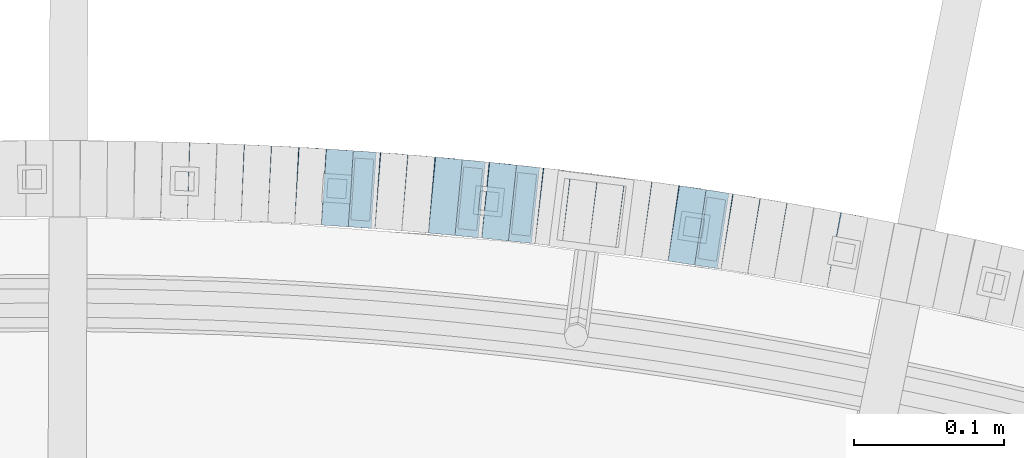
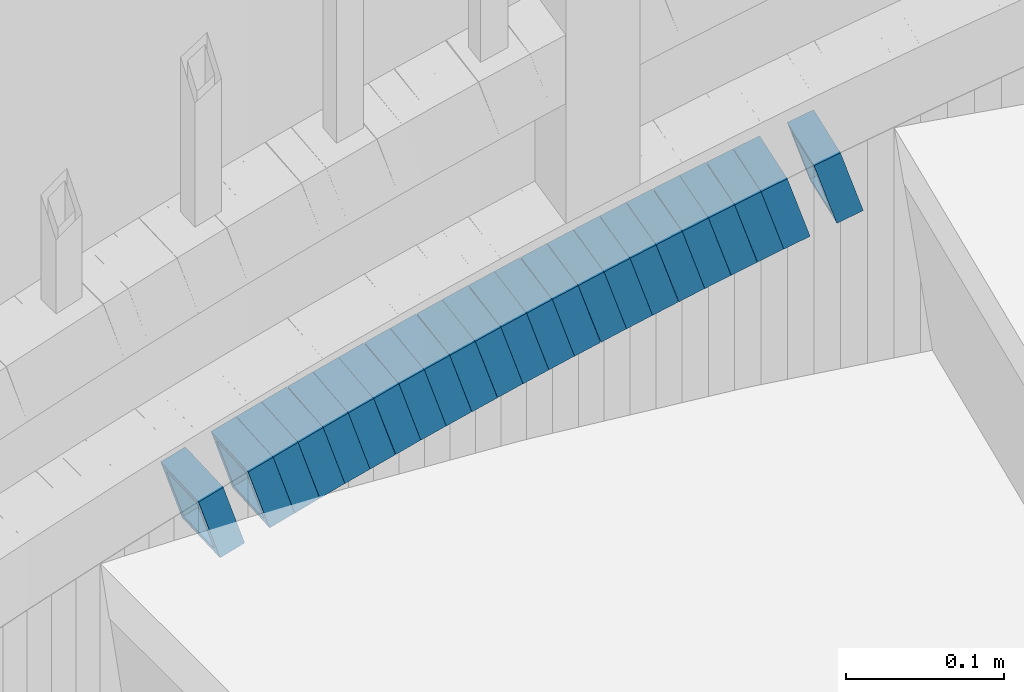
# One storey, part 820 of 975: 23 beams.
"""IFC2X3 building model written with IfcOpenShell, lengths in millimetres."""

from ifc_helpers import new_model, si_unit, frame, origin_with_axes, place, context, subcontext, project, spatial, faceted_brep, material, type_object, element, save


model = new_model("IFC2X3")

# Units and contexts
model_context = context("Model", 3, precision=1e-05, world=origin_with_axes())
body_context = subcontext(model_context, "Body", "Model", "MODEL_VIEW")
ifc_project = project(units=[si_unit("LENGTHUNIT", "METRE", prefix="MILLI"), si_unit("AREAUNIT", "SQUARE_METRE"), si_unit("VOLUMEUNIT", "CUBIC_METRE"), si_unit("MASSUNIT", "GRAM", prefix="KILO"), si_unit("TIMEUNIT", "SECOND"), si_unit("PLANEANGLEUNIT", "RADIAN"), si_unit("SOLIDANGLEUNIT", "STERADIAN"), si_unit("THERMODYNAMICTEMPERATUREUNIT", "DEGREE_CELSIUS"), si_unit("LUMINOUSINTENSITYUNIT", "LUMEN")], contexts=[model_context])

# Site, building, storey
site_placement = place(None, origin_with_axes())
site = spatial("IfcSite", under=ifc_project, at=site_placement, CompositionType="ELEMENT")
building_placement = place(site_placement, origin_with_axes())
building = spatial("IfcBuilding", under=site, at=building_placement, Name="Undefined", CompositionType="ELEMENT")
storey_placement = place(building_placement, origin_with_axes())
storey = spatial("IfcBuildingStorey", under=building, at=storey_placement, Name="Undefined", CompositionType="ELEMENT", Elevation=0.0)

# Beams
ifc_material = material()
beam_type = type_object("IfcBeamType", Name="HSS2X2X.188_TUBES", PredefinedType="NOTDEFINED")
beam_1_placement = place(storey_placement, frame((35262.2063020336, 6225.26838532403, 1208.89888890886), z_axis=(-0.178885438594422, -0.983869910028191, 3.69490862794919e-10), x_axis=(-0.937430905660929, 0.17044198293836, -0.303599781890188)))
element("IfcBeam", 1, at=beam_1_placement, inside=storey, type_object=beam_type, material=ifc_material, Name="WALL", ObjectType="HSS2X2X.188_TUBES", context=body_context, shape_type="Brep", body=[
    faceted_brep([(0.0, 20.6374999999753, -20.6375000000298), (0.0, -20.6375000000153, -20.6375000000153), (18.767258723612, -20.6375000000025, -20.6374999999862), (18.7672587236229, 20.6374999999953, -20.637499999968), (0.0, -20.6374999999825, 20.6375000000335), (18.767258723612, -20.6375000000135, 20.6375000000153), (0.0, 20.6375000000116, 20.6375000000189), (18.7672587236266, 20.6374999999844, 20.6375000000371), (0.0, 25.3999999999724, -25.4000000000342), (0.0, 25.400000000016, 25.4000000000196), (18.7672587236302, 25.3999999999814, 25.4000000000342), (18.7672587236229, 25.399999999996, -25.3999999999687), (0.0, -25.399999999976, 25.4000000000378), (18.7672587236157, -25.4000000000142, 25.400000000016), (0.0, -25.400000000016, -25.4000000000196), (18.767258723612, -25.4000000000015, -25.3999999999905)], [[[0, 1, 2, 3]], [[1, 4, 5, 2]], [[4, 6, 7, 5]], [[6, 0, 3, 7]], [[8, 9, 10, 11]], [[9, 12, 13, 10]], [[12, 14, 15, 13]], [[14, 8, 11, 15]], [[13, 15, 11, 10], [5, 7, 3, 2]], [[14, 12, 9, 8], [6, 4, 1, 0]]]),
])
beam_2_placement = place(storey_placement, frame((35226.658747704, 6231.69836351905, 1197.40322650701), z_axis=(-0.168030974253103, -0.985781716046485, 1.54325334733585e-10), x_axis=(-0.93908413016491, 0.160071159028105, -0.304135201053436)))
element("IfcBeam", 2, at=beam_2_placement, inside=storey, type_object=beam_type, material=ifc_material, Name="WALL", ObjectType="HSS2X2X.188_TUBES", context=body_context, shape_type="Brep", body=[
    faceted_brep([(0.0, 20.6374999999753, -20.6375000000298), (0.0, -20.6375000000153, -20.6375000000153), (18.7416648140024, -20.6375000000153, -20.6374999999825), (18.7416648139188, 20.6375000000189, -20.6375000000298), (0.0, -20.6374999999825, 20.6375000000335), (18.7416648140097, -20.6375000000189, 20.6375000000226), (0.0, 20.6375000000116, 20.6375000000189), (18.741664813926, 20.6375000000153, 20.6374999999753), (0.0, 25.3999999999724, -25.4000000000342), (0.0, 25.400000000016, 25.4000000000196), (18.7416648139224, 25.4000000000196, 25.3999999999687), (18.7416648139042, 25.4000000000233, -25.4000000000378), (0.0, -25.399999999976, 25.4000000000378), (18.7416648140133, -25.4000000000215, 25.4000000000269), (0.0, -25.400000000016, -25.4000000000196), (18.7416648140133, -25.4000000000196, -25.399999999976)], [[[0, 1, 2, 3]], [[1, 4, 5, 2]], [[4, 6, 7, 5]], [[6, 0, 3, 7]], [[8, 9, 10, 11]], [[9, 12, 13, 10]], [[12, 14, 15, 13]], [[14, 8, 11, 15]], [[13, 15, 11, 10], [5, 7, 3, 2]], [[14, 12, 9, 8], [6, 4, 1, 0]]]),
])
beam_3_placement = place(storey_placement, frame((35208.9947502894, 6234.75973884689, 1191.73219557075), z_axis=(-0.161686018393244, -0.986842252569345, 1.71110059454804e-10), x_axis=(-0.938968920147769, 0.15384236502417, -0.307684731048362)))
element("IfcBeam", 3, at=beam_3_placement, inside=storey, type_object=beam_type, material=ifc_material, Name="WALL", ObjectType="HSS2X2X.188_TUBES", context=body_context, shape_type="Brep", body=[
    faceted_brep([(0.0, 20.6374999999753, -20.6375000000298), (0.0, -20.6375000000153, -20.6375000000153), (18.8480768248774, -20.6374999999716, -20.6375000000735), (18.8480768249356, 20.6375000000153, -20.6375000000226), (0.0, -20.6374999999825, 20.6375000000335), (18.8480768249283, -20.6374999999935, 20.6374999999716), (0.0, 20.6375000000116, 20.6375000000189), (18.8480768249865, 20.6374999999935, 20.6375000000262), (0.0, 25.3999999999724, -25.4000000000342), (0.0, 25.400000000016, 25.4000000000196), (18.848076825001, 25.3999999999887, 25.4000000000378), (18.8480768249392, 25.4000000000142, -25.4000000000233), (0.0, -25.399999999976, 25.4000000000378), (18.8480768249283, -25.399999999996, 25.3999999999833), (0.0, -25.400000000016, -25.4000000000196), (18.8480768248664, -25.3999999999687, -25.4000000000779)], [[[0, 1, 2, 3]], [[1, 4, 5, 2]], [[4, 6, 7, 5]], [[6, 0, 3, 7]], [[8, 9, 10, 11]], [[9, 12, 13, 10]], [[12, 14, 15, 13]], [[14, 8, 11, 15]], [[13, 15, 11, 10], [5, 7, 3, 2]], [[14, 12, 9, 8], [6, 4, 1, 0]]]),
])
beam_4_placement = place(storey_placement, frame((35190.9814570241, 6237.78959239048, 1185.90925997112), z_axis=(-0.151635150261849, -0.988436533726403, -9.61329078563721e-11), x_axis=(-0.941378395041395, 0.144416004006362, -0.30487823001343)))
element("IfcBeam", 4, at=beam_4_placement, inside=storey, type_object=beam_type, material=ifc_material, Name="WALL", ObjectType="HSS2X2X.188_TUBES", context=body_context, shape_type="Brep", body=[
    faceted_brep([(0.0, 20.6374999999753, -20.6375000000298), (0.0, -20.6375000000153, -20.6375000000153), (18.6959888745805, -20.6374999999771, -20.6375000000407), (18.6959888746751, 20.637499999988, -20.6374999999716), (0.0, -20.6374999999825, 20.6375000000335), (18.6959888746969, -20.6375000000135, 20.6375000000371), (0.0, 20.6375000000116, 20.6375000000189), (18.6959888747988, 20.6374999999498, 20.6375000001062), (0.0, 25.3999999999724, -25.4000000000342), (0.0, 25.400000000016, 25.4000000000196), (18.695988874817, 25.3999999999414, 25.4000000001215), (18.6959888746678, 25.3999999999887, -25.399999999976), (0.0, -25.399999999976, 25.4000000000378), (18.6959888747042, -25.4000000000124, 25.4000000000378), (0.0, -25.400000000016, -25.4000000000196), (18.695988874555, -25.3999999999687, -25.4000000000597)], [[[0, 1, 2, 3]], [[1, 4, 5, 2]], [[4, 6, 7, 5]], [[6, 0, 3, 7]], [[8, 9, 10, 11]], [[9, 12, 13, 10]], [[12, 14, 15, 13]], [[14, 8, 11, 15]], [[13, 15, 11, 10], [5, 7, 3, 2]], [[14, 12, 9, 8], [6, 4, 1, 0]]]),
])
for number, where, z_axis, x_axis, name in (
    (5, (35173.322819567, 6240.50518047398, 1180.19687075573), (-0.150797989337356, -0.988564599007981, 2.08925030165119e-10), (-0.941982549776804, 0.14369225296595, -0.303350312928075), "WALL"),
    (6, (35155.4898876332, 6243.31159292335, 1174.53992485413), (-0.139854805609597, -0.990172022099141, -1.91347226063954e-10), (-0.941835845386871, 0.133027662054659, -0.308624175126755), "WALL"),
):
    element("IfcBeam", number, at=place(storey_placement, frame(where, z_axis=z_axis, x_axis=x_axis)), inside=storey, type_object=beam_type, material=ifc_material, Name=name, ObjectType="HSS2X2X.188_TUBES", context=body_context, shape_type="Brep", body=[
        faceted_brep([(0.0, 20.6374999999753, -20.6375000000298), (0.0, -20.6375000000153, -20.6375000000153), (18.7853666454903, -20.6375000000535, -20.6375000000326), (18.785366645363, 20.6374999999862, -20.6375000000044), (0.0, -20.6374999999825, 20.6375000000335), (18.785366645352, -20.6375000000007, 20.6374999999989), (0.0, 20.6375000000116, 20.6375000000189), (18.7853666453102, 20.6375000000025, 20.6374999999753), (0.0, 25.3999999999724, -25.4000000000342), (0.0, 25.400000000016, 25.4000000000196), (18.7853666452065, 25.4000000000451, 25.4000000000351), (18.7853666453739, 25.3999999999833, -25.400000000006), (0.0, -25.399999999976, 25.4000000000378), (18.7853666497213, -25.399999993424, 25.3999999995158), (0.0, -25.400000000016, -25.4000000000196), (18.7853666455194, -25.4000000000633, -25.4000000000406)], [[[0, 1, 2, 3]], [[1, 4, 5, 2]], [[4, 6, 7, 5]], [[6, 0, 3, 7]], [[8, 9, 10, 11]], [[9, 12, 13, 10]], [[12, 14, 15, 13]], [[14, 8, 11, 15]], [[13, 15, 11, 10], [5, 7, 3, 2]], [[14, 12, 9, 8], [6, 4, 1, 0]]]),
    ])
beam_5_placement = place(storey_placement, frame((35137.540226941, 6245.8896922411, 1168.70220925751), z_axis=(-0.134363672851374, -0.990932088196708, 5.54321104573319e-11), x_axis=(-0.944030209558858, 0.128004096075806, -0.304009728179996)))
element("IfcBeam", 7, at=beam_5_placement, inside=storey, type_object=beam_type, material=ifc_material, Name="WALL", ObjectType="HSS2X2X.188_TUBES", context=body_context, shape_type="Brep", body=[
    faceted_brep([(0.0, 20.6374999999753, -20.6375000000298), (0.0, -20.6375000000153, -20.6375000000153), (18.7547327359644, -20.6374999999844, -20.6375000000553), (18.7547327359898, 20.6375000000171, -20.6375000000335), (0.0, -20.6374999999825, 20.6375000000335), (18.7547327360044, -20.6374999999953, 20.6374999999898), (0.0, 20.6375000000116, 20.6375000000189), (18.7547327360262, 20.6375000000062, 20.6375000000116), (0.0, 25.3999999999724, -25.4000000000342), (0.0, 25.400000000016, 25.4000000000196), (18.7547327360371, 25.4000000000033, 25.4000000000124), (18.7547327359898, 25.4000000000178, -25.4000000000342), (0.0, -25.399999999976, 25.4000000000378), (18.7547327360044, -25.399999999996, 25.3999999999869), (0.0, -25.400000000016, -25.4000000000196), (18.7547327359498, -25.3999999999814, -25.4000000000597)], [[[0, 1, 2, 3]], [[1, 4, 5, 2]], [[4, 6, 7, 5]], [[6, 0, 3, 7]], [[8, 9, 10, 11]], [[9, 12, 13, 10]], [[12, 14, 15, 13]], [[14, 8, 11, 15]], [[13, 15, 11, 10], [5, 7, 3, 2]], [[14, 12, 9, 8], [6, 4, 1, 0]]]),
])
beam_6_placement = place(storey_placement, frame((35119.7112034117, 6248.3500834073, 1163.00385877007), z_axis=(-0.128860134810282, -0.991662778194622, 6.80909124639584e-11), x_axis=(-0.94466191513395, 0.122752678017421, -0.304213159043145)))
element("IfcBeam", 8, at=beam_6_placement, inside=storey, type_object=beam_type, material=ifc_material, Name="WALL", ObjectType="HSS2X2X.188_TUBES", context=body_context, shape_type="Brep", body=[
    faceted_brep([(0.0, 20.6374999999753, -20.6375000000298), (0.0, -20.6375000000153, -20.6375000000153), (18.7416648140024, -20.6375000000153, -20.6374999999825), (18.7416648139188, 20.6375000000189, -20.6375000000298), (0.0, -20.6374999999825, 20.6375000000335), (18.7416648140097, -20.6375000000189, 20.6375000000226), (0.0, 20.6375000000116, 20.6375000000189), (18.741664813926, 20.6375000000153, 20.6374999999753), (0.0, 25.3999999999724, -25.4000000000342), (0.0, 25.400000000016, 25.4000000000196), (18.7416648139224, 25.4000000000196, 25.3999999999687), (18.7416648139042, 25.4000000000233, -25.4000000000378), (0.0, -25.399999999976, 25.4000000000378), (18.7416648140133, -25.4000000000215, 25.4000000000269), (0.0, -25.400000000016, -25.4000000000196), (18.7416648140133, -25.4000000000196, -25.399999999976)], [[[0, 1, 2, 3]], [[1, 4, 5, 2]], [[4, 6, 7, 5]], [[6, 0, 3, 7]], [[8, 9, 10, 11]], [[9, 12, 13, 10]], [[12, 14, 15, 13]], [[14, 8, 11, 15]], [[13, 15, 11, 10], [5, 7, 3, 2]], [[14, 12, 9, 8], [6, 4, 1, 0]]]),
])
beam_7_placement = place(storey_placement, frame((35102.0032873235, 6250.69475441336, 1157.34502291689), z_axis=(-0.123344664337536, -0.992363891815629, 2.06378899747506e-10), x_axis=(-0.943721538367322, 0.117298722045631, -0.309242086120369)))
element("IfcBeam", 9, at=beam_7_placement, inside=storey, type_object=beam_type, material=ifc_material, Name="WALL", ObjectType="HSS2X2X.188_TUBES", context=body_context, shape_type="Brep", body=[
    faceted_brep([(0.0, 20.6374999999753, -20.6375000000298), (0.0, -20.6375000000153, -20.6375000000153), (18.7555325170906, -20.6374999999916, -20.6374999999971), (18.7555325171452, 20.637499999988, -20.6374999999571), (0.0, -20.6374999999825, 20.6375000000335), (18.7555325170615, -20.6374999999844, 20.6374999999716), (0.0, 20.6375000000116, 20.6375000000189), (18.7555325171015, 20.6374999999953, 20.637500000008), (0.0, 25.3999999999724, -25.4000000000342), (0.0, 25.400000000016, 25.4000000000196), (18.7555325171015, 25.399999999996, 25.4000000000051), (18.7555325171488, 25.3999999999851, -25.3999999999505), (0.0, -25.399999999976, 25.4000000000378), (18.755532517047, -25.3999999999814, 25.3999999999578), (0.0, -25.400000000016, -25.4000000000196), (18.7555325170979, -25.3999999999924, -25.3999999999978)], [[[0, 1, 2, 3]], [[1, 4, 5, 2]], [[4, 6, 7, 5]], [[6, 0, 3, 7]], [[8, 9, 10, 11]], [[9, 12, 13, 10]], [[12, 14, 15, 13]], [[14, 8, 11, 15]], [[13, 15, 11, 10], [5, 7, 3, 2]], [[14, 12, 9, 8], [6, 4, 1, 0]]]),
])
beam_8_placement = place(storey_placement, frame((35083.9963321529, 6252.98069752095, 1151.49454788734), z_axis=(-0.117164953610452, -0.993112467772639, 1.14559497887967e-10), x_axis=(-0.946406940559044, 0.111654750947981, -0.303062896858747)))
element("IfcBeam", 10, at=beam_8_placement, inside=storey, type_object=beam_type, material=ifc_material, Name="WALL", ObjectType="HSS2X2X.188_TUBES", context=body_context, shape_type="Brep", body=[
    faceted_brep([(0.0, 20.6374999999753, -20.6375000000298), (0.0, -20.6375000000153, -20.6375000000153), (18.8066477608099, -20.6374999999862, -20.6375000000116), (18.8066477608172, 20.6375000000062, -20.6374999999971), (0.0, -20.6374999999825, 20.6375000000335), (18.8066477608463, -20.6375000000062, 20.6375000000407), (0.0, 20.6375000000116, 20.6375000000189), (18.8066477608536, 20.6374999999844, 20.637500000048), (0.0, 25.3999999999724, -25.4000000000342), (0.0, 25.400000000016, 25.4000000000196), (18.8066477608591, 25.3999999999814, 25.400000000056), (18.8066477608154, 25.4000000000051, -25.4000000000015), (0.0, -25.399999999976, 25.4000000000378), (18.8066477608518, -25.4000000000087, 25.4000000000451), (0.0, -25.400000000016, -25.4000000000196), (18.8066477608081, -25.3999999999851, -25.4000000000196)], [[[0, 1, 2, 3]], [[1, 4, 5, 2]], [[4, 6, 7, 5]], [[6, 0, 3, 7]], [[8, 9, 10, 11]], [[9, 12, 13, 10]], [[12, 14, 15, 13]], [[14, 8, 11, 15]], [[13, 15, 11, 10], [5, 7, 3, 2]], [[14, 12, 9, 8], [6, 4, 1, 0]]]),
])
beam_9_placement = place(storey_placement, frame((35065.9878684266, 6255.18576919674, 1145.80979211206), z_axis=(-0.106731467305159, -0.994287882802002, 2.14446572499583e-10), x_axis=(-0.946930338465777, 0.101647889050011, -0.304943668149982)))
element("IfcBeam", 11, at=beam_9_placement, inside=storey, type_object=beam_type, material=ifc_material, Name="WALL", ObjectType="HSS2X2X.188_TUBES", context=body_context, shape_type="Brep", body=[
    faceted_brep([(0.0, 20.6374999999753, -20.6375000000298), (0.0, -20.6375000000153, -20.6375000000153), (18.6895692834223, -20.637499999988, -20.6374999999862), (18.6895692834369, 20.6374999999953, -20.6374999999534), (0.0, -20.6374999999825, 20.6375000000335), (18.6895692833914, -20.637499999988, 20.6374999999789), (0.0, 20.6375000000116, 20.6375000000189), (18.6895692834078, 20.6374999999953, 20.637500000008), (0.0, 25.3999999999724, -25.4000000000342), (0.0, 25.400000000016, 25.4000000000196), (18.6895692834059, 25.3999999999924, 25.4000000000087), (18.6895692834423, 25.3999999999942, -25.3999999999432), (0.0, -25.399999999976, 25.4000000000378), (18.6895692833878, -25.3999999999869, 25.3999999999687), (0.0, -25.400000000016, -25.4000000000196), (18.6895692834241, -25.3999999999869, -25.3999999999833)], [[[0, 1, 2, 3]], [[1, 4, 5, 2]], [[4, 6, 7, 5]], [[6, 0, 3, 7]], [[8, 9, 10, 11]], [[9, 12, 13, 10]], [[12, 14, 15, 13]], [[14, 8, 11, 15]], [[13, 15, 11, 10], [5, 7, 3, 2]], [[14, 12, 9, 8], [6, 4, 1, 0]]]),
])
beam_10_placement = place(storey_placement, frame((35048.2344700465, 6257.09611792352, 1140.09732250904), z_axis=(-0.10613862675189, -0.994351342288641, -2.28305907512549e-10), x_axis=(-0.947478931466103, 0.101135391943019, -0.30340617482903)))
element("IfcBeam", 12, at=beam_10_placement, inside=storey, type_object=beam_type, material=ifc_material, Name="WALL", ObjectType="HSS2X2X.188_TUBES", context=body_context, shape_type="Brep", body=[
    faceted_brep([(0.0, 20.6374999999753, -20.6375000000298), (0.0, -20.6375000000153, -20.6375000000153), (18.7853666454903, -20.6375000000535, -20.6375000000326), (18.785366645363, 20.6374999999862, -20.6375000000044), (0.0, -20.6374999999825, 20.6375000000335), (18.785366645352, -20.6375000000007, 20.6374999999989), (0.0, 20.6375000000116, 20.6375000000189), (18.7853666453102, 20.6375000000025, 20.6374999999753), (0.0, 25.3999999999724, -25.4000000000342), (0.0, 25.400000000016, 25.4000000000196), (18.7853666452065, 25.4000000000451, 25.4000000000351), (18.7853666453739, 25.3999999999833, -25.400000000006), (0.0, -25.399999999976, 25.4000000000378), (18.7853666497213, -25.399999993424, 25.3999999995158), (0.0, -25.400000000016, -25.4000000000196), (18.7853666455194, -25.4000000000633, -25.4000000000406)], [[[0, 1, 2, 3]], [[1, 4, 5, 2]], [[4, 6, 7, 5]], [[6, 0, 3, 7]], [[8, 9, 10, 11]], [[9, 12, 13, 10]], [[12, 14, 15, 13]], [[14, 8, 11, 15]], [[13, 15, 11, 10], [5, 7, 3, 2]], [[14, 12, 9, 8], [6, 4, 1, 0]]]),
])
beam_11_placement = place(storey_placement, frame((35030.2918652597, 6259.09741657967, 1134.43924107346), z_axis=(-0.0950730065790194, -0.995470302630885, -1.98346697288798e-10), x_axis=(-0.946902283782616, 0.0904344879792262, -0.30854119392911)))
element("IfcBeam", 13, at=beam_11_placement, inside=storey, type_object=beam_type, material=ifc_material, Name="WALL", ObjectType="HSS2X2X.188_TUBES", context=body_context, shape_type="Brep", body=[
    faceted_brep([(0.0, 20.6374999999753, -20.6375000000298), (0.0, -20.6375000000153, -20.6375000000153), (18.8047866246379, -20.6374999999916, -20.6375000000298), (18.8047866247143, 20.6374999999844, -20.6374999999643), (0.0, -20.6374999999825, 20.6375000000335), (18.8047866247107, -20.6375000000189, 20.6375000000407), (0.0, 20.6375000000116, 20.6375000000189), (18.8047866247907, 20.6374999999589, 20.6375000001026), (0.0, 25.3999999999724, -25.4000000000342), (0.0, 25.400000000016, 25.4000000000196), (18.8047866248016, 25.3999999999542, 25.4000000001142), (18.8047866247143, 25.3999999999851, -25.3999999999651), (0.0, -25.399999999976, 25.4000000000378), (18.8047866247107, -25.4000000000196, 25.4000000000415), (0.0, -25.400000000016, -25.4000000000196), (18.8047866246197, -25.3999999999887, -25.4000000000378)], [[[0, 1, 2, 3]], [[1, 4, 5, 2]], [[4, 6, 7, 5]], [[6, 0, 3, 7]], [[8, 9, 10, 11]], [[9, 12, 13, 10]], [[12, 14, 15, 13]], [[14, 8, 11, 15]], [[13, 15, 11, 10], [5, 7, 3, 2]], [[14, 12, 9, 8], [6, 4, 1, 0]]]),
])
beam_12_placement = place(storey_placement, frame((35012.4219826033, 6260.79992261746, 1128.61235292574), z_axis=(-0.0956052464452732, -0.995419327144163, -1.37664756039157e-10), x_axis=(-0.947907534808326, 0.0910419669816003, -0.305258358938331)))
element("IfcBeam", 14, at=beam_12_placement, inside=storey, type_object=beam_type, material=ifc_material, Name="WALL", ObjectType="HSS2X2X.188_TUBES", context=body_context, shape_type="Brep", body=[
    faceted_brep([(0.0, 20.6374999999753, -20.6375000000298), (0.0, -20.6375000000153, -20.6375000000153), (18.6689581926366, -20.6374999999953, -20.6374999999916), (18.6689581926476, 20.6375000000062, -20.6374999999935), (0.0, -20.6374999999825, 20.6375000000335), (18.6689581927276, -20.6375000000116, 20.6374999999862), (0.0, 20.6375000000116, 20.6375000000189), (18.6689581927312, 20.6374999999862, 20.6374999999844), (0.0, 25.3999999999724, -25.4000000000342), (0.0, 25.400000000016, 25.4000000000196), (18.6689581927458, 25.3999999999833, 25.3999999999814), (18.6689581926366, 25.4000000000087, -25.3999999999905), (0.0, -25.399999999976, 25.4000000000378), (18.6689581927385, -25.4000000000142, 25.3999999999851), (0.0, -25.400000000016, -25.4000000000196), (18.6689581926257, -25.3999999999887, -25.3999999999869)], [[[0, 1, 2, 3]], [[1, 4, 5, 2]], [[4, 6, 7, 5]], [[6, 0, 3, 7]], [[8, 9, 10, 11]], [[9, 12, 13, 10]], [[12, 14, 15, 13]], [[14, 8, 11, 15]], [[13, 15, 11, 10], [5, 7, 3, 2]], [[14, 12, 9, 8], [6, 4, 1, 0]]]),
])
beam_13_placement = place(storey_placement, frame((34994.4025898593, 6262.61946067607, 1122.9020690823), z_axis=(-0.0839720319663465, -0.996468111806616, 5.51881385035813e-12), x_axis=(-0.949309706342227, 0.0799980090288366, -0.303992434109563)))
element("IfcBeam", 15, at=beam_13_placement, inside=storey, type_object=beam_type, material=ifc_material, Name="WALL", ObjectType="HSS2X2X.188_TUBES", context=body_context, shape_type="Brep", body=[
    faceted_brep([(0.0, 20.6374999999753, -20.6375000000298), (0.0, -20.6375000000153, -20.6375000000153), (18.7547327359644, -20.6374999999844, -20.6375000000553), (18.7547327359898, 20.6375000000171, -20.6375000000335), (0.0, -20.6374999999825, 20.6375000000335), (18.7547327360044, -20.6374999999953, 20.6374999999898), (0.0, 20.6375000000116, 20.6375000000189), (18.7547327360262, 20.6375000000062, 20.6375000000116), (0.0, 25.3999999999724, -25.4000000000342), (0.0, 25.400000000016, 25.4000000000196), (18.7547327360371, 25.4000000000033, 25.4000000000124), (18.7547327359898, 25.4000000000178, -25.4000000000342), (0.0, -25.399999999976, 25.4000000000378), (18.7547327360044, -25.399999999996, 25.3999999999869), (0.0, -25.400000000016, -25.4000000000196), (18.7547327359498, -25.3999999999814, -25.4000000000597)], [[[0, 1, 2, 3]], [[1, 4, 5, 2]], [[4, 6, 7, 5]], [[6, 0, 3, 7]], [[8, 9, 10, 11]], [[9, 12, 13, 10]], [[12, 14, 15, 13]], [[14, 8, 11, 15]], [[13, 15, 11, 10], [5, 7, 3, 2]], [[14, 12, 9, 8], [6, 4, 1, 0]]]),
])
beam_14_placement = place(storey_placement, frame((34976.4679778304, 6264.1736704105, 1117.20308609433), z_axis=(-0.0784095351627402, -0.996921232994645, -5.19273726240499e-11), x_axis=(-0.949701466907224, 0.0746956209927166, -0.304117884970253)))
element("IfcBeam", 16, at=beam_14_placement, inside=storey, type_object=beam_type, material=ifc_material, Name="WALL", ObjectType="HSS2X2X.188_TUBES", context=body_context, shape_type="Brep", body=[
    faceted_brep([(0.0, 20.6374999999753, -20.6375000000298), (0.0, -20.6375000000153, -20.6375000000153), (18.7416648140024, -20.6375000000153, -20.6374999999825), (18.7416648139188, 20.6375000000189, -20.6375000000298), (0.0, -20.6374999999825, 20.6375000000335), (18.7416648140097, -20.6375000000189, 20.6375000000226), (0.0, 20.6375000000116, 20.6375000000189), (18.741664813926, 20.6375000000153, 20.6374999999753), (0.0, 25.3999999999724, -25.4000000000342), (0.0, 25.400000000016, 25.4000000000196), (18.7416648139224, 25.4000000000196, 25.3999999999687), (18.7416648139042, 25.4000000000233, -25.4000000000378), (0.0, -25.399999999976, 25.4000000000378), (18.7416648140133, -25.4000000000215, 25.4000000000269), (0.0, -25.400000000016, -25.4000000000196), (18.7416648140133, -25.4000000000196, -25.399999999976)], [[[0, 1, 2, 3]], [[1, 4, 5, 2]], [[4, 6, 7, 5]], [[6, 0, 3, 7]], [[8, 9, 10, 11]], [[9, 12, 13, 10]], [[12, 14, 15, 13]], [[14, 8, 11, 15]], [[13, 15, 11, 10], [5, 7, 3, 2]], [[14, 12, 9, 8], [6, 4, 1, 0]]]),
])
beam_15_placement = place(storey_placement, frame((34958.5193348877, 6265.67180717767, 1111.54447857671), z_axis=(-0.0672630522607651, -0.997735276413822, 1.4846455087536e-10), x_axis=(-0.948851018029315, 0.0639674840019809, -0.309176174009557)))
element("IfcBeam", 17, at=beam_15_placement, inside=storey, type_object=beam_type, material=ifc_material, Name="WALL", ObjectType="HSS2X2X.188_TUBES", context=body_context, shape_type="Brep", body=[
    faceted_brep([(0.0, 20.6374999999753, -20.6375000000298), (0.0, -20.6375000000153, -20.6375000000153), (18.7555325170906, -20.6374999999916, -20.6374999999971), (18.7555325171452, 20.637499999988, -20.6374999999571), (0.0, -20.6374999999825, 20.6375000000335), (18.7555325170615, -20.6374999999844, 20.6374999999716), (0.0, 20.6375000000116, 20.6375000000189), (18.7555325171015, 20.6374999999953, 20.637500000008), (0.0, 25.3999999999724, -25.4000000000342), (0.0, 25.400000000016, 25.4000000000196), (18.7555325171015, 25.399999999996, 25.4000000000051), (18.7555325171488, 25.3999999999851, -25.3999999999505), (0.0, -25.399999999976, 25.4000000000378), (18.755532517047, -25.3999999999814, 25.3999999999578), (0.0, -25.400000000016, -25.4000000000196), (18.7555325170979, -25.3999999999924, -25.3999999999978)], [[[0, 1, 2, 3]], [[1, 4, 5, 2]], [[4, 6, 7, 5]], [[6, 0, 3, 7]], [[8, 9, 10, 11]], [[9, 12, 13, 10]], [[12, 14, 15, 13]], [[14, 8, 11, 15]], [[13, 15, 11, 10], [5, 7, 3, 2]], [[14, 12, 9, 8], [6, 4, 1, 0]]]),
])
beam_16_placement = place(storey_placement, frame((34940.548595662, 6266.88620613172, 1105.69247535054), z_axis=(-0.0668889670804565, -0.997760425193799, -2.13867679121904e-11), x_axis=(-0.95091772047031, 0.0637486740315257, -0.302806201149798)))
element("IfcBeam", 18, at=beam_16_placement, inside=storey, type_object=beam_type, material=ifc_material, Name="WALL", ObjectType="HSS2X2X.188_TUBES", context=body_context, shape_type="Brep", body=[
    faceted_brep([(0.0, 20.6374999999753, -20.6375000000298), (0.0, -20.6375000000153, -20.6375000000153), (18.8225928075335, -20.6374999999935, -20.6375000000298), (18.8225928075699, 20.6374999999898, -20.6374999999825), (0.0, -20.6374999999825, 20.6375000000335), (18.8225928075772, -20.637500000008, 20.6375000000226), (0.0, 20.6375000000116, 20.6375000000189), (18.8225928076135, 20.6374999999753, 20.6375000000698), (0.0, 25.3999999999724, -25.4000000000342), (0.0, 25.400000000016, 25.4000000000196), (18.8225928076281, 25.3999999999705, 25.4000000000815), (18.8225928075663, 25.3999999999905, -25.3999999999796), (0.0, -25.399999999976, 25.4000000000378), (18.8225928075808, -25.4000000000087, 25.4000000000233), (0.0, -25.400000000016, -25.4000000000196), (18.8225928075226, -25.3999999999905, -25.4000000000378)], [[[0, 1, 2, 3]], [[1, 4, 5, 2]], [[4, 6, 7, 5]], [[6, 0, 3, 7]], [[8, 9, 10, 11]], [[9, 12, 13, 10]], [[12, 14, 15, 13]], [[14, 8, 11, 15]], [[13, 15, 11, 10], [5, 7, 3, 2]], [[14, 12, 9, 8], [6, 4, 1, 0]]]),
])
beam_17_placement = place(storey_placement, frame((34922.5603677066, 6268.13222751255, 1100.00572430057), z_axis=(-0.0616800884415207, -0.9980959706811, -1.47135096995044e-10), x_axis=(-0.950716893774201, 0.0587521679860311, -0.304443049927695)))
element("IfcBeam", 19, at=beam_17_placement, inside=storey, type_object=beam_type, material=ifc_material, Name="WALL", ObjectType="HSS2X2X.188_TUBES", context=body_context, shape_type="Brep", body=[
    faceted_brep([(0.0, 20.6374999999753, -20.6375000000298), (0.0, -20.6375000000153, -20.6375000000153), (18.724849799155, -20.6375000000171, -20.6374999999425), (18.7248497991204, 20.6374999999989, -20.6375000000007), (0.0, -20.6374999999825, 20.6375000000335), (18.7248497991168, -20.6374999999953, 20.6375000000007), (0.0, 20.6375000000116, 20.6375000000189), (18.724849799084, 20.6375000000226, 20.6374999999498), (0.0, 25.3999999999724, -25.4000000000342), (0.0, 25.400000000016, 25.4000000000196), (18.7248497990731, 25.4000000000269, 25.399999999936), (18.7248497991204, 25.3999999999978, -25.3999999999978), (0.0, -25.399999999976, 25.4000000000378), (18.7248497991186, -25.3999999999942, 25.4000000000051), (0.0, -25.400000000016, -25.4000000000196), (18.7248497991604, -25.4000000000233, -25.3999999999323)], [[[0, 1, 2, 3]], [[1, 4, 5, 2]], [[4, 6, 7, 5]], [[6, 0, 3, 7]], [[8, 9, 10, 11]], [[9, 12, 13, 10]], [[12, 14, 15, 13]], [[14, 8, 11, 15]], [[13, 15, 11, 10], [5, 7, 3, 2]], [[14, 12, 9, 8], [6, 4, 1, 0]]]),
])
beam_18_placement = place(storey_placement, frame((34904.5616568957, 6269.33279573335, 1094.33390484472), z_axis=(-0.0502158966098432, -0.998738386028929, 1.26572558656335e-10), x_axis=(-0.950220743318243, 0.0477764620159912, -0.307892755103072)))
element("IfcBeam", 20, at=beam_18_placement, inside=storey, type_object=beam_type, material=ifc_material, Name="WALL", ObjectType="HSS2X2X.188_TUBES", context=body_context, shape_type="Brep", body=[
    faceted_brep([(0.0, 20.6374999999753, -20.6375000000298), (0.0, -20.6375000000153, -20.6375000000153), (18.8433011969464, -20.6374999999898, -20.6375000000226), (18.8433011969719, 20.6375000000007, -20.6374999999862), (0.0, -20.6374999999825, 20.6375000000335), (18.8433011969828, -20.6375000000044, 20.6375000000189), (0.0, 20.6375000000116, 20.6375000000189), (18.8433011970155, 20.6374999999862, 20.6375000000517), (0.0, 25.3999999999724, -25.4000000000342), (0.0, 25.400000000016, 25.4000000000196), (18.8433011970228, 25.3999999999833, 25.4000000000597), (18.8433011969719, 25.4000000000015, -25.3999999999869), (0.0, -25.399999999976, 25.4000000000378), (18.8433011969864, -25.4000000000051, 25.4000000000196), (0.0, -25.400000000016, -25.4000000000196), (18.8433011969391, -25.3999999999869, -25.4000000000269)], [[[0, 1, 2, 3]], [[1, 4, 5, 2]], [[4, 6, 7, 5]], [[6, 0, 3, 7]], [[8, 9, 10, 11]], [[9, 12, 13, 10]], [[12, 14, 15, 13]], [[14, 8, 11, 15]], [[13, 15, 11, 10], [5, 7, 3, 2]], [[14, 12, 9, 8], [6, 4, 1, 0]]]),
])
beam_19_placement = place(storey_placement, frame((34868.4638273702, 6271.1372030049, 1082.79576019949), z_axis=(-0.0390762776090196, -0.999236230592257, -1.98707084564376e-10), x_axis=(-0.95219501401685, 0.0372366770006359, -0.303212937005335)))
element("IfcBeam", 21, at=beam_19_placement, inside=storey, type_object=beam_type, material=ifc_material, Name="WALL", ObjectType="HSS2X2X.188_TUBES", context=body_context, shape_type="Brep", body=[
    faceted_brep([(0.0, 20.6374999999753, -20.6375000000298), (0.0, -20.6375000000153, -20.6375000000153), (18.8047866246379, -20.6374999999916, -20.6375000000298), (18.8047866247143, 20.6374999999844, -20.6374999999643), (0.0, -20.6374999999825, 20.6375000000335), (18.8047866247107, -20.6375000000189, 20.6375000000407), (0.0, 20.6375000000116, 20.6375000000189), (18.8047866247907, 20.6374999999589, 20.6375000001026), (0.0, 25.3999999999724, -25.4000000000342), (0.0, 25.400000000016, 25.4000000000196), (18.8047866248016, 25.3999999999542, 25.4000000001142), (18.8047866247143, 25.3999999999851, -25.3999999999651), (0.0, -25.399999999976, 25.4000000000378), (18.8047866247107, -25.4000000000196, 25.4000000000415), (0.0, -25.400000000016, -25.4000000000196), (18.8047866246197, -25.3999999999887, -25.4000000000378)], [[[0, 1, 2, 3]], [[1, 4, 5, 2]], [[4, 6, 7, 5]], [[6, 0, 3, 7]], [[8, 9, 10, 11]], [[9, 12, 13, 10]], [[12, 14, 15, 13]], [[14, 8, 11, 15]], [[13, 15, 11, 10], [5, 7, 3, 2]], [[14, 12, 9, 8], [6, 4, 1, 0]]]),
])
beam_20_placement = place(storey_placement, frame((34886.4473290848, 6270.28446229099, 1088.50773709326), z_axis=(-0.044898496675909, -0.998991554016471, -2.07617631531321e-10), x_axis=(-0.951490800323582, 0.0427636310145616, -0.304690874103639)))
element("IfcBeam", 22, at=beam_20_placement, inside=storey, type_object=beam_type, material=ifc_material, Name="WALL", ObjectType="HSS2X2X.188_TUBES", context=body_context, shape_type="Brep", body=[
    faceted_brep([(0.0, 20.6374999999753, -20.6375000000298), (0.0, -20.6375000000153, -20.6375000000153), (18.7112265765609, -20.6375000000062, -20.6374999999862), (18.7112265765645, 20.6374999999898, -20.6374999999789), (0.0, -20.6374999999825, 20.6375000000335), (18.7112265765209, -20.6374999999916, 20.6374999999607), (0.0, 20.6375000000116, 20.6375000000189), (18.7112265765245, 20.6375000000025, 20.6374999999716), (0.0, 25.3999999999724, -25.4000000000342), (0.0, 25.400000000016, 25.4000000000196), (18.7112265765172, 25.4000000000051, 25.3999999999614), (18.7112265765718, 25.3999999999887, -25.3999999999724), (0.0, -25.399999999976, 25.4000000000378), (18.7112265765136, -25.3999999999905, 25.3999999999542), (0.0, -25.400000000016, -25.4000000000196), (18.7112265765682, -25.4000000000069, -25.3999999999796)], [[[0, 1, 2, 3]], [[1, 4, 5, 2]], [[4, 6, 7, 5]], [[6, 0, 3, 7]], [[8, 9, 10, 11]], [[9, 12, 13, 10]], [[12, 14, 15, 13]], [[14, 8, 11, 15]], [[13, 15, 11, 10], [5, 7, 3, 2]], [[14, 12, 9, 8], [6, 4, 1, 0]]]),
])
beam_21_placement = place(storey_placement, frame((34832.4291762439, 6272.53011076484, 1071.30911814602), z_axis=(-0.0280788118241107, -0.99960571243193, 6.01623924012529e-11), x_axis=(-0.952021405617908, 0.0267421739892749, -0.3048607868776)))
element("IfcBeam", 23, at=beam_21_placement, inside=storey, type_object=beam_type, material=ifc_material, Name="WALL", ObjectType="HSS2X2X.188_TUBES", context=body_context, shape_type="Brep", body=[
    faceted_brep([(0.0, 20.6374999999753, -20.6375000000298), (0.0, -20.6375000000153, -20.6375000000153), (18.6959888745805, -20.6374999999771, -20.6375000000407), (18.6959888746751, 20.637499999988, -20.6374999999716), (0.0, -20.6374999999825, 20.6375000000335), (18.6959888746969, -20.6375000000135, 20.6375000000371), (0.0, 20.6375000000116, 20.6375000000189), (18.6959888747988, 20.6374999999498, 20.6375000001062), (0.0, 25.3999999999724, -25.4000000000342), (0.0, 25.400000000016, 25.4000000000196), (18.695988874817, 25.3999999999414, 25.4000000001215), (18.6959888746678, 25.3999999999887, -25.399999999976), (0.0, -25.399999999976, 25.4000000000378), (18.6959888747042, -25.4000000000124, 25.4000000000378), (0.0, -25.400000000016, -25.4000000000196), (18.695988874555, -25.3999999999687, -25.4000000000597)], [[[0, 1, 2, 3]], [[1, 4, 5, 2]], [[4, 6, 7, 5]], [[6, 0, 3, 7]], [[8, 9, 10, 11]], [[9, 12, 13, 10]], [[12, 14, 15, 13]], [[14, 8, 11, 15]], [[13, 15, 11, 10], [5, 7, 3, 2]], [[14, 12, 9, 8], [6, 4, 1, 0]]]),
])

save(model, "model.ifc")
